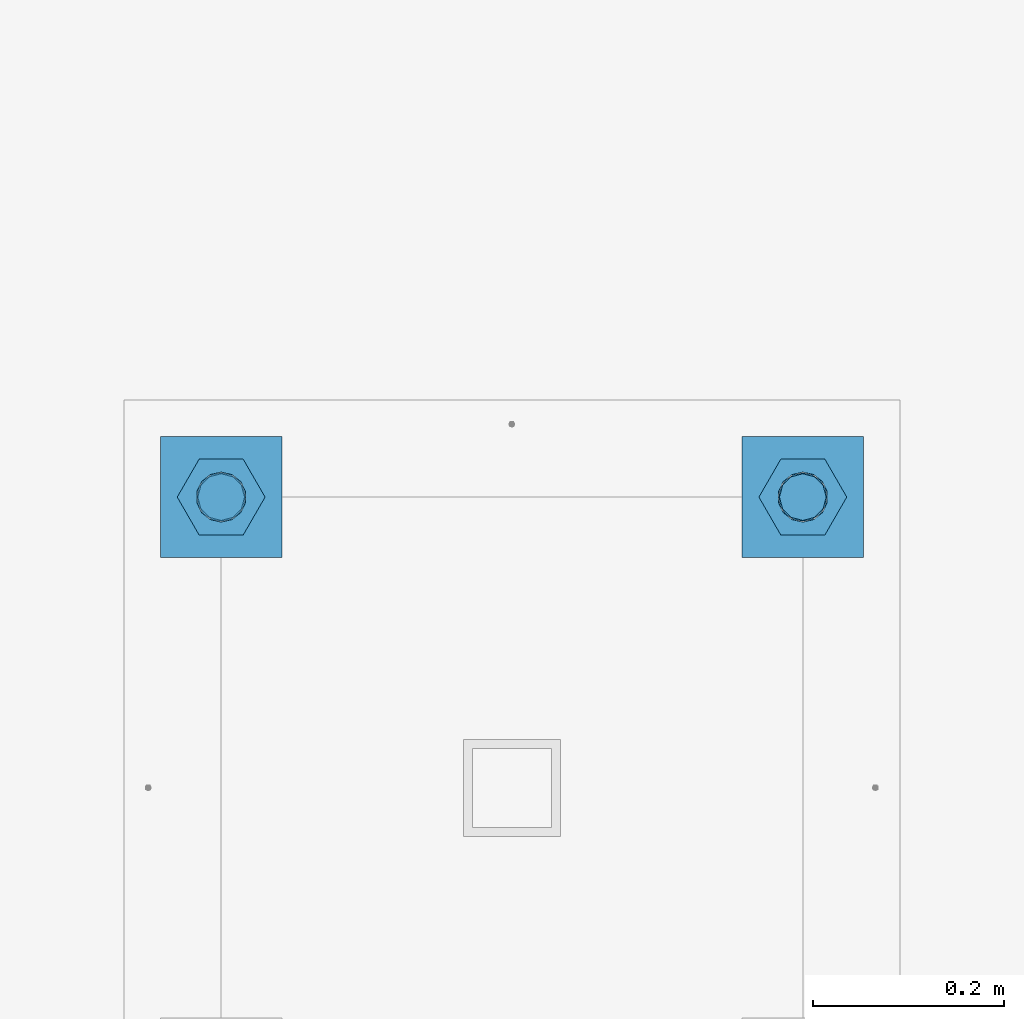
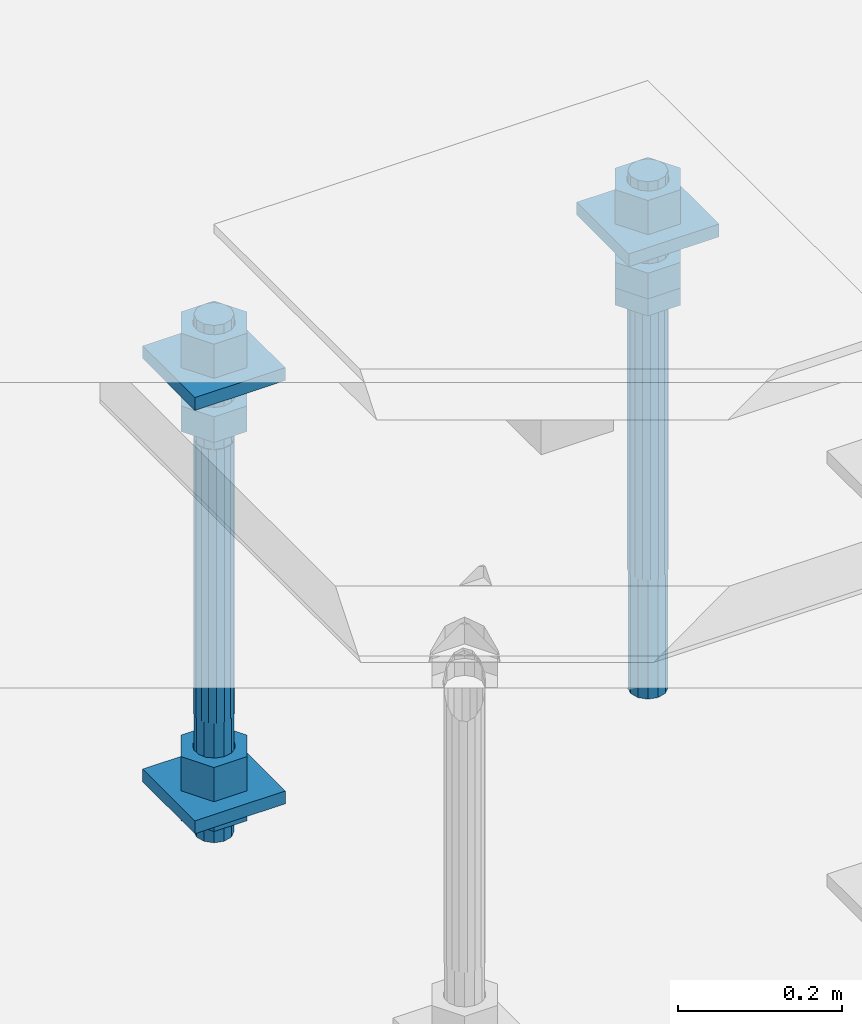
# One storey, part 2744 of 3843: 12 beams, 1 element without a shape of its own.
"""IFC2X3 building model written with IfcOpenShell, lengths in millimetres."""

from ifc_helpers import new_model, si_unit, frame, origin_with_axes, place, context, subcontext, project, spatial, faceted_brep, material, type_object, element, aggregate, save


model = new_model("IFC2X3")

# Units and contexts
model_context = context("Model", 3, precision=1e-05, world=origin_with_axes())
body_context = subcontext(model_context, "Body", "Model", "MODEL_VIEW")
ifc_project = project(units=[si_unit("LENGTHUNIT", "METRE", prefix="MILLI"), si_unit("AREAUNIT", "SQUARE_METRE"), si_unit("VOLUMEUNIT", "CUBIC_METRE"), si_unit("MASSUNIT", "GRAM", prefix="KILO"), si_unit("TIMEUNIT", "SECOND"), si_unit("PLANEANGLEUNIT", "RADIAN"), si_unit("SOLIDANGLEUNIT", "STERADIAN"), si_unit("THERMODYNAMICTEMPERATUREUNIT", "DEGREE_CELSIUS"), si_unit("LUMINOUSINTENSITYUNIT", "LUMEN")], contexts=[model_context])

# Site, building, storey
site_placement = place(None, origin_with_axes())
site = spatial("IfcSite", under=ifc_project, at=site_placement, CompositionType="ELEMENT")
building_placement = place(site_placement, origin_with_axes())
building = spatial("IfcBuilding", under=site, at=building_placement, Name="Undefined", CompositionType="ELEMENT")
storey_placement = place(building_placement, origin_with_axes())
storey = spatial("IfcBuildingStorey", under=building, at=storey_placement, Name="Undefined", CompositionType="ELEMENT", Elevation=0.0)

# Assembly, beams
assembly_placement = place(storey_placement, origin_with_axes())
assembly = element("IfcElementAssembly", 1, at=assembly_placement, inside=storey, Name="TEMPLATE", AssemblyPlace="NOTDEFINED", PredefinedType="RIGID_FRAME")
ifc_material_1 = material(Name="STEEL/A36")
beam_type_1 = type_object("IfcBeamType", PredefinedType="NOTDEFINED")
beam_1_placement = place(assembly_placement, frame((111734.6, 42113.2000015259, 29873.575), z_axis=(1.0, 0.0, 0.0), x_axis=(0.0, 1.0, 0.0)))
beam_1 = element("IfcBeam", 2, at=beam_1_placement, type_object=beam_type_1, material=ifc_material_1, Name="WASHER_PLATE", context=body_context, shape_type="Brep", body=[
    faceted_brep([(0.0, 9.52500000000146, -63.5), (0.0, 9.52500000000146, 63.5), (127.0, 9.52500000000146, 63.5), (127.0, 9.52500000000146, -63.5), (0.0, -9.52500000000146, 63.5), (127.0, -9.52500000000146, 63.5), (0.0, -9.52500000000146, -63.5), (127.0, -9.52500000000146, -63.5)], [[[0, 1, 2, 3]], [[1, 4, 5, 2]], [[4, 6, 7, 5]], [[6, 0, 3, 7]], [[5, 7, 3, 2]], [[6, 4, 1, 0]]]),
])
beam_2_placement = place(assembly_placement, frame((112344.2, 42113.2000015259, 29873.575), z_axis=(1.0, 0.0, 0.0), x_axis=(0.0, 1.0, 0.0)))
beam_2 = element("IfcBeam", 3, at=beam_2_placement, type_object=beam_type_1, material=ifc_material_1, Name="WASHER_PLATE", context=body_context, shape_type="Brep", body=[
    faceted_brep([(0.0, 9.52500000000146, -63.5), (0.0, 9.52500000000146, 63.5), (127.0, 9.52500000000146, 63.5), (127.0, 9.52500000000146, -63.5), (0.0, -9.52500000000146, 63.5), (127.0, -9.52500000000146, 63.5), (0.0, -9.52500000000146, -63.5), (127.0, -9.52500000000146, -63.5)], [[[0, 1, 2, 3]], [[1, 4, 5, 2]], [[4, 6, 7, 5]], [[6, 0, 3, 7]], [[5, 7, 3, 2]], [[6, 4, 1, 0]]]),
])
beam_3_placement = place(assembly_placement, frame((111734.6, 42113.2000015259, 29244.925), z_axis=(1.0, 0.0, 0.0), x_axis=(0.0, 1.0, 0.0)))
beam_3 = element("IfcBeam", 4, at=beam_3_placement, type_object=beam_type_1, material=ifc_material_1, Name="WASHER_PLATE", context=body_context, shape_type="Brep", body=[
    faceted_brep([(0.0, 9.52500000000146, -63.5), (0.0, 9.52500000000146, 63.5), (127.0, 9.52500000000146, 63.5), (127.0, 9.52500000000146, -63.5), (0.0, -9.52500000000146, 63.5), (127.0, -9.52500000000146, 63.5), (0.0, -9.52500000000146, -63.5), (127.0, -9.52500000000146, -63.5)], [[[0, 1, 2, 3]], [[1, 4, 5, 2]], [[4, 6, 7, 5]], [[6, 0, 3, 7]], [[5, 7, 3, 2]], [[6, 4, 1, 0]]]),
])
beam_type_2 = type_object("IfcBeamType", Name="2_HALF_NUT", PredefinedType="NOTDEFINED")
beam_4_placement = place(assembly_placement, frame((112344.2, 42176.7000015259, 29787.85), z_axis=(0.0, 1.0, 0.0), x_axis=(0.0, 0.0, -1.0)))
beam_4 = element("IfcBeam", 5, at=beam_4_placement, type_object=beam_type_2, material=ifc_material_1, Name="NUT", ObjectType="2_HALF_NUT", context=body_context, shape_type="Brep", body=[
    faceted_brep([(0.0, -46.0369987487793, 0.0), (0.0, -23.0184993743896, -39.869213104248), (25.4000000000015, -23.0184993743896, -39.869213104248), (25.4000000000015, -46.0369987487793, 0.0), (0.0, 23.0184993743896, -39.869213104248), (25.4000000000015, 23.0184993743896, -39.869213104248), (0.0, 46.0369987487793, 0.0), (25.4000000000015, 46.0369987487793, 0.0), (0.0, 23.0184993743896, 39.869213104248), (25.4000000000015, 23.0184993743896, 39.869213104248), (0.0, -23.0184993743896, 39.869213104248), (25.4000000000015, -23.0184993743896, 39.869213104248), (0.0, 0.0, 26.1940002441406), (0.0, 11.3650617044477, 23.5999013092805), (25.4000000000015, 11.3650617044477, 23.5999013092805), (25.4000000000015, 0.0, 26.1940002441406), (0.0, 20.4791109456419, 16.3316083006721), (25.4000000000015, 20.4791109456419, 16.3316083006721), (0.0, 25.5370200498292, 5.82867859874386), (25.4000000000015, 25.5370200498292, 5.82867859874386), (0.0, 25.5370200498292, -5.82867859874386), (25.4000000000015, 25.5370200498292, -5.82867859874386), (0.0, 20.4791109456419, -16.3316083006721), (25.4000000000015, 20.4791109456419, -16.3316083006721), (0.0, 11.3650617044477, -23.5999013092805), (25.4000000000015, 11.3650617044477, -23.5999013092805), (0.0, 0.0, -26.1940002441406), (25.4000000000015, 0.0, -26.1940002441406), (0.0, -11.3650617044477, -23.5999013092805), (25.4000000000015, -11.3650617044477, -23.5999013092805), (0.0, -20.4791109456419, -16.3316083006721), (25.4000000000015, -20.4791109456419, -16.3316083006721), (0.0, -25.5370200498292, -5.82867859874386), (25.4000000000015, -25.5370200498292, -5.82867859874386), (0.0, -25.5370200498292, 5.82867859874386), (25.4000000000015, -25.5370200498292, 5.82867859874386), (0.0, -20.4791109456419, 16.3316083006721), (25.4000000000015, -20.4791109456419, 16.3316083006721), (0.0, -11.3650617044477, 23.5999013092805), (25.4000000000015, -11.3650617044477, 23.5999013092805)], [[[0, 1, 2, 3]], [[1, 4, 5, 2]], [[4, 6, 7, 5]], [[6, 8, 9, 7]], [[8, 10, 11, 9]], [[10, 0, 3, 11]], [[12, 13, 14, 15]], [[13, 16, 17, 14]], [[16, 18, 19, 17]], [[18, 20, 21, 19]], [[20, 22, 23, 21]], [[22, 24, 25, 23]], [[24, 26, 27, 25]], [[26, 28, 29, 27]], [[28, 30, 31, 29]], [[30, 32, 33, 31]], [[32, 34, 35, 33]], [[34, 36, 37, 35]], [[36, 38, 39, 37]], [[38, 12, 15, 39]], [[5, 7, 9, 11, 3, 2], [17, 19, 21, 23, 25, 27, 29, 31, 33, 35, 37, 39, 15, 14]], [[10, 8, 6, 4, 1, 0], [38, 36, 34, 32, 30, 28, 26, 24, 22, 20, 18, 16, 13, 12]]]),
])
beam_5_placement = place(assembly_placement, frame((111734.6, 42176.7000015259, 29235.4), z_axis=(0.0, 1.0, 0.0), x_axis=(0.0, 0.0, -1.0)))
beam_5 = element("IfcBeam", 6, at=beam_5_placement, type_object=beam_type_2, material=ifc_material_1, Name="NUT", ObjectType="2_HALF_NUT", context=body_context, shape_type="Brep", body=[
    faceted_brep([(0.0, -46.0369987487793, 0.0), (0.0, -23.0184993743896, -39.869213104248), (25.4000000000015, -23.0184993743896, -39.869213104248), (25.4000000000015, -46.0369987487793, 0.0), (0.0, 23.0184993743896, -39.869213104248), (25.4000000000015, 23.0184993743896, -39.869213104248), (0.0, 46.0369987487793, 0.0), (25.4000000000015, 46.0369987487793, 0.0), (0.0, 23.0184993743896, 39.869213104248), (25.4000000000015, 23.0184993743896, 39.869213104248), (0.0, -23.0184993743896, 39.869213104248), (25.4000000000015, -23.0184993743896, 39.869213104248), (0.0, 0.0, 26.1940002441406), (0.0, 11.3650617044477, 23.5999013092805), (25.4000000000015, 11.3650617044477, 23.5999013092805), (25.4000000000015, 0.0, 26.1940002441406), (0.0, 20.4791109456419, 16.3316083006721), (25.4000000000015, 20.4791109456419, 16.3316083006721), (0.0, 25.5370200498292, 5.82867859874386), (25.4000000000015, 25.5370200498292, 5.82867859874386), (0.0, 25.5370200498292, -5.82867859874386), (25.4000000000015, 25.5370200498292, -5.82867859874386), (0.0, 20.4791109456419, -16.3316083006721), (25.4000000000015, 20.4791109456419, -16.3316083006721), (0.0, 11.3650617044477, -23.5999013092805), (25.4000000000015, 11.3650617044477, -23.5999013092805), (0.0, 0.0, -26.1940002441406), (25.4000000000015, 0.0, -26.1940002441406), (0.0, -11.3650617044477, -23.5999013092805), (25.4000000000015, -11.3650617044477, -23.5999013092805), (0.0, -20.4791109456419, -16.3316083006721), (25.4000000000015, -20.4791109456419, -16.3316083006721), (0.0, -25.5370200498292, -5.82867859874386), (25.4000000000015, -25.5370200498292, -5.82867859874386), (0.0, -25.5370200498292, 5.82867859874386), (25.4000000000015, -25.5370200498292, 5.82867859874386), (0.0, -20.4791109456419, 16.3316083006721), (25.4000000000015, -20.4791109456419, 16.3316083006721), (0.0, -11.3650617044477, 23.5999013092805), (25.4000000000015, -11.3650617044477, 23.5999013092805)], [[[0, 1, 2, 3]], [[1, 4, 5, 2]], [[4, 6, 7, 5]], [[6, 8, 9, 7]], [[8, 10, 11, 9]], [[10, 0, 3, 11]], [[12, 13, 14, 15]], [[13, 16, 17, 14]], [[16, 18, 19, 17]], [[18, 20, 21, 19]], [[20, 22, 23, 21]], [[22, 24, 25, 23]], [[24, 26, 27, 25]], [[26, 28, 29, 27]], [[28, 30, 31, 29]], [[30, 32, 33, 31]], [[32, 34, 35, 33]], [[34, 36, 37, 35]], [[36, 38, 39, 37]], [[38, 12, 15, 39]], [[5, 7, 9, 11, 3, 2], [17, 19, 21, 23, 25, 27, 29, 31, 33, 35, 37, 39, 15, 14]], [[10, 8, 6, 4, 1, 0], [38, 36, 34, 32, 30, 28, 26, 24, 22, 20, 18, 16, 13, 12]]]),
])
beam_type_3 = type_object("IfcBeamType", Name="2_HEAVY_HEX_NUT", PredefinedType="NOTDEFINED")
beam_6_placement = place(assembly_placement, frame((111734.6, 42176.7000015259, 29825.95), z_axis=(0.0, 1.0, 0.0), x_axis=(0.0, 0.0, -1.0)))
beam_6 = element("IfcBeam", 7, at=beam_6_placement, type_object=beam_type_3, material=ifc_material_1, Name="NUT", ObjectType="2_HEAVY_HEX_NUT", context=body_context, shape_type="Brep", body=[
    faceted_brep([(0.0, -46.0369987487793, 0.0), (0.0, -23.0184993743896, -39.869213104248), (38.0999999999985, -23.0184993743896, -39.869213104248), (38.0999999999985, -46.0369987487793, 0.0), (0.0, 23.0184993743896, -39.869213104248), (38.0999999999985, 23.0184993743896, -39.869213104248), (0.0, 46.0369987487793, 0.0), (38.0999999999985, 46.0369987487793, 0.0), (0.0, 23.0184993743896, 39.869213104248), (38.0999999999985, 23.0184993743896, 39.869213104248), (0.0, -23.0184993743896, 39.869213104248), (38.0999999999985, -23.0184993743896, 39.869213104248), (0.0, 0.0, 26.1940002441406), (0.0, 11.3650617044477, 23.5999013092805), (38.0999999999985, 11.3650617044477, 23.5999013092805), (38.0999999999985, 0.0, 26.1940002441406), (0.0, 20.4791109456419, 16.3316083006721), (38.0999999999985, 20.4791109456419, 16.3316083006721), (0.0, 25.5370200498292, 5.82867859874386), (38.0999999999985, 25.5370200498292, 5.82867859874386), (0.0, 25.5370200498292, -5.82867859874386), (38.0999999999985, 25.5370200498292, -5.82867859874386), (0.0, 20.4791109456419, -16.3316083006721), (38.0999999999985, 20.4791109456419, -16.3316083006721), (0.0, 11.3650617044477, -23.5999013092805), (38.0999999999985, 11.3650617044477, -23.5999013092805), (0.0, 0.0, -26.1940002441406), (38.0999999999985, 0.0, -26.1940002441406), (0.0, -11.3650617044477, -23.5999013092805), (38.0999999999985, -11.3650617044477, -23.5999013092805), (0.0, -20.4791109456419, -16.3316083006721), (38.0999999999985, -20.4791109456419, -16.3316083006721), (0.0, -25.5370200498292, -5.82867859874386), (38.0999999999985, -25.5370200498292, -5.82867859874386), (0.0, -25.5370200498292, 5.82867859874386), (38.0999999999985, -25.5370200498292, 5.82867859874386), (0.0, -20.4791109456419, 16.3316083006721), (38.0999999999985, -20.4791109456419, 16.3316083006721), (0.0, -11.3650617044477, 23.5999013092805), (38.0999999999985, -11.3650617044477, 23.5999013092805)], [[[0, 1, 2, 3]], [[1, 4, 5, 2]], [[4, 6, 7, 5]], [[6, 8, 9, 7]], [[8, 10, 11, 9]], [[10, 0, 3, 11]], [[12, 13, 14, 15]], [[13, 16, 17, 14]], [[16, 18, 19, 17]], [[18, 20, 21, 19]], [[20, 22, 23, 21]], [[22, 24, 25, 23]], [[24, 26, 27, 25]], [[26, 28, 29, 27]], [[28, 30, 31, 29]], [[30, 32, 33, 31]], [[32, 34, 35, 33]], [[34, 36, 37, 35]], [[36, 38, 39, 37]], [[38, 12, 15, 39]], [[5, 7, 9, 11, 3, 2], [17, 19, 21, 23, 25, 27, 29, 31, 33, 35, 37, 39, 15, 14]], [[10, 8, 6, 4, 1, 0], [38, 36, 34, 32, 30, 28, 26, 24, 22, 20, 18, 16, 13, 12]]]),
])
beam_7_placement = place(assembly_placement, frame((111734.6, 42176.7000015259, 29933.9), z_axis=(0.0, 1.0, 0.0), x_axis=(0.0, 0.0, -1.0)))
beam_7 = element("IfcBeam", 8, at=beam_7_placement, type_object=beam_type_3, material=ifc_material_1, Name="NUT", ObjectType="2_HEAVY_HEX_NUT", context=body_context, shape_type="Brep", body=[
    faceted_brep([(0.0, -46.0369987487793, 0.0), (0.0, -23.0184993743896, -39.869213104248), (50.7999999999993, -23.0184993743896, -39.869213104248), (50.7999999999993, -46.0369987487793, 0.0), (0.0, 23.0184993743896, -39.869213104248), (50.7999999999993, 23.0184993743896, -39.869213104248), (0.0, 46.0369987487793, 0.0), (50.7999999999993, 46.0369987487793, 0.0), (0.0, 23.0184993743896, 39.869213104248), (50.7999999999993, 23.0184993743896, 39.869213104248), (0.0, -23.0184993743896, 39.869213104248), (50.7999999999993, -23.0184993743896, 39.869213104248), (0.0, 0.0, 26.1940002441406), (0.0, 11.3650617044477, 23.5999013092805), (50.7999999999993, 11.3650617044477, 23.5999013092805), (50.7999999999993, 0.0, 26.1940002441406), (0.0, 20.4791109456419, 16.3316083006721), (50.7999999999993, 20.4791109456419, 16.3316083006721), (0.0, 25.5370200498292, 5.82867859874386), (50.7999999999993, 25.5370200498292, 5.82867859874386), (0.0, 25.5370200498292, -5.82867859874386), (50.7999999999993, 25.5370200498292, -5.82867859874386), (0.0, 20.4791109456419, -16.3316083006721), (50.7999999999993, 20.4791109456419, -16.3316083006721), (0.0, 11.3650617044477, -23.5999013092805), (50.7999999999993, 11.3650617044477, -23.5999013092805), (0.0, 0.0, -26.1940002441406), (50.7999999999993, 0.0, -26.1940002441406), (0.0, -11.3650617044477, -23.5999013092805), (50.7999999999993, -11.3650617044477, -23.5999013092805), (0.0, -20.4791109456419, -16.3316083006721), (50.7999999999993, -20.4791109456419, -16.3316083006721), (0.0, -25.5370200498292, -5.82867859874386), (50.7999999999993, -25.5370200498292, -5.82867859874386), (0.0, -25.5370200498292, 5.82867859874386), (50.7999999999993, -25.5370200498292, 5.82867859874386), (0.0, -20.4791109456419, 16.3316083006721), (50.7999999999993, -20.4791109456419, 16.3316083006721), (0.0, -11.3650617044477, 23.5999013092805), (50.7999999999993, -11.3650617044477, 23.5999013092805)], [[[0, 1, 2, 3]], [[1, 4, 5, 2]], [[4, 6, 7, 5]], [[6, 8, 9, 7]], [[8, 10, 11, 9]], [[10, 0, 3, 11]], [[12, 13, 14, 15]], [[13, 16, 17, 14]], [[16, 18, 19, 17]], [[18, 20, 21, 19]], [[20, 22, 23, 21]], [[22, 24, 25, 23]], [[24, 26, 27, 25]], [[26, 28, 29, 27]], [[28, 30, 31, 29]], [[30, 32, 33, 31]], [[32, 34, 35, 33]], [[34, 36, 37, 35]], [[36, 38, 39, 37]], [[38, 12, 15, 39]], [[5, 7, 9, 11, 3, 2], [17, 19, 21, 23, 25, 27, 29, 31, 33, 35, 37, 39, 15, 14]], [[10, 8, 6, 4, 1, 0], [38, 36, 34, 32, 30, 28, 26, 24, 22, 20, 18, 16, 13, 12]]]),
])
beam_8_placement = place(assembly_placement, frame((111734.6, 42176.7000015259, 29305.25), z_axis=(0.0, 1.0, 0.0), x_axis=(0.0, 0.0, -1.0)))
beam_8 = element("IfcBeam", 9, at=beam_8_placement, type_object=beam_type_3, material=ifc_material_1, Name="NUT", ObjectType="2_HEAVY_HEX_NUT", context=body_context, shape_type="Brep", body=[
    faceted_brep([(0.0, -46.0369987487793, 0.0), (0.0, -23.0184993743896, -39.869213104248), (50.7999999999993, -23.0184993743896, -39.869213104248), (50.7999999999993, -46.0369987487793, 0.0), (0.0, 23.0184993743896, -39.869213104248), (50.7999999999993, 23.0184993743896, -39.869213104248), (0.0, 46.0369987487793, 0.0), (50.7999999999993, 46.0369987487793, 0.0), (0.0, 23.0184993743896, 39.869213104248), (50.7999999999993, 23.0184993743896, 39.869213104248), (0.0, -23.0184993743896, 39.869213104248), (50.7999999999993, -23.0184993743896, 39.869213104248), (0.0, 0.0, 26.1940002441406), (0.0, 11.3650617044477, 23.5999013092805), (50.7999999999993, 11.3650617044477, 23.5999013092805), (50.7999999999993, 0.0, 26.1940002441406), (0.0, 20.4791109456419, 16.3316083006721), (50.7999999999993, 20.4791109456419, 16.3316083006721), (0.0, 25.5370200498292, 5.82867859874386), (50.7999999999993, 25.5370200498292, 5.82867859874386), (0.0, 25.5370200498292, -5.82867859874386), (50.7999999999993, 25.5370200498292, -5.82867859874386), (0.0, 20.4791109456419, -16.3316083006721), (50.7999999999993, 20.4791109456419, -16.3316083006721), (0.0, 11.3650617044477, -23.5999013092805), (50.7999999999993, 11.3650617044477, -23.5999013092805), (0.0, 0.0, -26.1940002441406), (50.7999999999993, 0.0, -26.1940002441406), (0.0, -11.3650617044477, -23.5999013092805), (50.7999999999993, -11.3650617044477, -23.5999013092805), (0.0, -20.4791109456419, -16.3316083006721), (50.7999999999993, -20.4791109456419, -16.3316083006721), (0.0, -25.5370200498292, -5.82867859874386), (50.7999999999993, -25.5370200498292, -5.82867859874386), (0.0, -25.5370200498292, 5.82867859874386), (50.7999999999993, -25.5370200498292, 5.82867859874386), (0.0, -20.4791109456419, 16.3316083006721), (50.7999999999993, -20.4791109456419, 16.3316083006721), (0.0, -11.3650617044477, 23.5999013092805), (50.7999999999993, -11.3650617044477, 23.5999013092805)], [[[0, 1, 2, 3]], [[1, 4, 5, 2]], [[4, 6, 7, 5]], [[6, 8, 9, 7]], [[8, 10, 11, 9]], [[10, 0, 3, 11]], [[12, 13, 14, 15]], [[13, 16, 17, 14]], [[16, 18, 19, 17]], [[18, 20, 21, 19]], [[20, 22, 23, 21]], [[22, 24, 25, 23]], [[24, 26, 27, 25]], [[26, 28, 29, 27]], [[28, 30, 31, 29]], [[30, 32, 33, 31]], [[32, 34, 35, 33]], [[34, 36, 37, 35]], [[36, 38, 39, 37]], [[38, 12, 15, 39]], [[5, 7, 9, 11, 3, 2], [17, 19, 21, 23, 25, 27, 29, 31, 33, 35, 37, 39, 15, 14]], [[10, 8, 6, 4, 1, 0], [38, 36, 34, 32, 30, 28, 26, 24, 22, 20, 18, 16, 13, 12]]]),
])
beam_9_placement = place(assembly_placement, frame((112344.2, 42176.7000015259, 29825.95), z_axis=(0.0, 1.0, 0.0), x_axis=(0.0, 0.0, -1.0)))
beam_9 = element("IfcBeam", 10, at=beam_9_placement, type_object=beam_type_3, material=ifc_material_1, Name="NUT", ObjectType="2_HEAVY_HEX_NUT", context=body_context, shape_type="Brep", body=[
    faceted_brep([(0.0, -46.0369987487793, 0.0), (0.0, -23.0184993743896, -39.869213104248), (38.0999999999985, -23.0184993743896, -39.869213104248), (38.0999999999985, -46.0369987487793, 0.0), (0.0, 23.0184993743896, -39.869213104248), (38.0999999999985, 23.0184993743896, -39.869213104248), (0.0, 46.0369987487793, 0.0), (38.0999999999985, 46.0369987487793, 0.0), (0.0, 23.0184993743896, 39.869213104248), (38.0999999999985, 23.0184993743896, 39.869213104248), (0.0, -23.0184993743896, 39.869213104248), (38.0999999999985, -23.0184993743896, 39.869213104248), (0.0, 0.0, 26.1940002441406), (0.0, 11.3650617044477, 23.5999013092805), (38.0999999999985, 11.3650617044477, 23.5999013092805), (38.0999999999985, 0.0, 26.1940002441406), (0.0, 20.4791109456419, 16.3316083006721), (38.0999999999985, 20.4791109456419, 16.3316083006721), (0.0, 25.5370200498292, 5.82867859874386), (38.0999999999985, 25.5370200498292, 5.82867859874386), (0.0, 25.5370200498292, -5.82867859874386), (38.0999999999985, 25.5370200498292, -5.82867859874386), (0.0, 20.4791109456419, -16.3316083006721), (38.0999999999985, 20.4791109456419, -16.3316083006721), (0.0, 11.3650617044477, -23.5999013092805), (38.0999999999985, 11.3650617044477, -23.5999013092805), (0.0, 0.0, -26.1940002441406), (38.0999999999985, 0.0, -26.1940002441406), (0.0, -11.3650617044477, -23.5999013092805), (38.0999999999985, -11.3650617044477, -23.5999013092805), (0.0, -20.4791109456419, -16.3316083006721), (38.0999999999985, -20.4791109456419, -16.3316083006721), (0.0, -25.5370200498292, -5.82867859874386), (38.0999999999985, -25.5370200498292, -5.82867859874386), (0.0, -25.5370200498292, 5.82867859874386), (38.0999999999985, -25.5370200498292, 5.82867859874386), (0.0, -20.4791109456419, 16.3316083006721), (38.0999999999985, -20.4791109456419, 16.3316083006721), (0.0, -11.3650617044477, 23.5999013092805), (38.0999999999985, -11.3650617044477, 23.5999013092805)], [[[0, 1, 2, 3]], [[1, 4, 5, 2]], [[4, 6, 7, 5]], [[6, 8, 9, 7]], [[8, 10, 11, 9]], [[10, 0, 3, 11]], [[12, 13, 14, 15]], [[13, 16, 17, 14]], [[16, 18, 19, 17]], [[18, 20, 21, 19]], [[20, 22, 23, 21]], [[22, 24, 25, 23]], [[24, 26, 27, 25]], [[26, 28, 29, 27]], [[28, 30, 31, 29]], [[30, 32, 33, 31]], [[32, 34, 35, 33]], [[34, 36, 37, 35]], [[36, 38, 39, 37]], [[38, 12, 15, 39]], [[5, 7, 9, 11, 3, 2], [17, 19, 21, 23, 25, 27, 29, 31, 33, 35, 37, 39, 15, 14]], [[10, 8, 6, 4, 1, 0], [38, 36, 34, 32, 30, 28, 26, 24, 22, 20, 18, 16, 13, 12]]]),
])
beam_10_placement = place(assembly_placement, frame((112344.2, 42176.7000015259, 29933.9), z_axis=(0.0, 1.0, 0.0), x_axis=(0.0, 0.0, -1.0)))
beam_10 = element("IfcBeam", 11, at=beam_10_placement, type_object=beam_type_3, material=ifc_material_1, Name="NUT", ObjectType="2_HEAVY_HEX_NUT", context=body_context, shape_type="Brep", body=[
    faceted_brep([(0.0, -46.0369987487793, 0.0), (0.0, -23.0184993743896, -39.869213104248), (50.7999999999993, -23.0184993743896, -39.869213104248), (50.7999999999993, -46.0369987487793, 0.0), (0.0, 23.0184993743896, -39.869213104248), (50.7999999999993, 23.0184993743896, -39.869213104248), (0.0, 46.0369987487793, 0.0), (50.7999999999993, 46.0369987487793, 0.0), (0.0, 23.0184993743896, 39.869213104248), (50.7999999999993, 23.0184993743896, 39.869213104248), (0.0, -23.0184993743896, 39.869213104248), (50.7999999999993, -23.0184993743896, 39.869213104248), (0.0, 0.0, 26.1940002441406), (0.0, 11.3650617044477, 23.5999013092805), (50.7999999999993, 11.3650617044477, 23.5999013092805), (50.7999999999993, 0.0, 26.1940002441406), (0.0, 20.4791109456419, 16.3316083006721), (50.7999999999993, 20.4791109456419, 16.3316083006721), (0.0, 25.5370200498292, 5.82867859874386), (50.7999999999993, 25.5370200498292, 5.82867859874386), (0.0, 25.5370200498292, -5.82867859874386), (50.7999999999993, 25.5370200498292, -5.82867859874386), (0.0, 20.4791109456419, -16.3316083006721), (50.7999999999993, 20.4791109456419, -16.3316083006721), (0.0, 11.3650617044477, -23.5999013092805), (50.7999999999993, 11.3650617044477, -23.5999013092805), (0.0, 0.0, -26.1940002441406), (50.7999999999993, 0.0, -26.1940002441406), (0.0, -11.3650617044477, -23.5999013092805), (50.7999999999993, -11.3650617044477, -23.5999013092805), (0.0, -20.4791109456419, -16.3316083006721), (50.7999999999993, -20.4791109456419, -16.3316083006721), (0.0, -25.5370200498292, -5.82867859874386), (50.7999999999993, -25.5370200498292, -5.82867859874386), (0.0, -25.5370200498292, 5.82867859874386), (50.7999999999993, -25.5370200498292, 5.82867859874386), (0.0, -20.4791109456419, 16.3316083006721), (50.7999999999993, -20.4791109456419, 16.3316083006721), (0.0, -11.3650617044477, 23.5999013092805), (50.7999999999993, -11.3650617044477, 23.5999013092805)], [[[0, 1, 2, 3]], [[1, 4, 5, 2]], [[4, 6, 7, 5]], [[6, 8, 9, 7]], [[8, 10, 11, 9]], [[10, 0, 3, 11]], [[12, 13, 14, 15]], [[13, 16, 17, 14]], [[16, 18, 19, 17]], [[18, 20, 21, 19]], [[20, 22, 23, 21]], [[22, 24, 25, 23]], [[24, 26, 27, 25]], [[26, 28, 29, 27]], [[28, 30, 31, 29]], [[30, 32, 33, 31]], [[32, 34, 35, 33]], [[34, 36, 37, 35]], [[36, 38, 39, 37]], [[38, 12, 15, 39]], [[5, 7, 9, 11, 3, 2], [17, 19, 21, 23, 25, 27, 29, 31, 33, 35, 37, 39, 15, 14]], [[10, 8, 6, 4, 1, 0], [38, 36, 34, 32, 30, 28, 26, 24, 22, 20, 18, 16, 13, 12]]]),
])
ifc_material_2 = material()
beam_type_4 = type_object("IfcBeamType", PredefinedType="NOTDEFINED")
beam_11_placement = place(assembly_placement, frame((111734.6, 42176.7000015259, 29762.45), z_axis=(0.0, 1.0, 0.0), x_axis=(0.0, 0.0, -1.0)))
beam_11 = element("IfcBeam", 12, at=beam_11_placement, type_object=beam_type_4, material=ifc_material_2, Name="ANCHOR_ROD", context=body_context, shape_type="Brep", body=[
    faceted_brep([(-184.150000000001, -21.217622392709, 12.25), (-184.150000000001, -12.2499999999854, 21.2176223927163), (-184.150000000001, 1.45519152283669e-11, 24.5), (-184.150000000001, 12.2500000000146, 21.2176223927163), (-184.150000000001, 21.2176223927381, 12.25), (-184.150000000001, 24.5000000000146, 0.0), (-184.150000000001, 21.2176223927381, -12.25), (-184.150000000001, 12.2500000000146, -21.2176223927163), (-184.150000000001, 1.45519152283669e-11, -24.5), (-184.150000000001, -12.2499999999854, -21.2176223927163), (-184.150000000001, -21.217622392709, -12.25), (-184.150000000001, -24.4999999999854, 0.0), (0.0, 24.5000000000146, 0.0), (0.0, 21.2176223927381, -12.25), (0.0, 12.2500000000146, -21.2176223927163), (0.0, 1.45519152283669e-11, -24.5), (0.0, -12.2499999999854, -21.2176223927163), (0.0, -21.217622392709, -12.25), (0.0, -24.4999999999854, 0.0), (0.0, -21.217622392709, 12.25), (0.0, -12.2499999999854, 21.2176223927163), (0.0, 1.45519152283669e-11, 24.5), (0.0, 12.2500000000146, 21.2176223927163), (0.0, 21.2176223927381, 12.25), (0.0, -23.4665401257807, 9.72015918207035), (0.0, -17.9605122421344, 17.9605122421417), (0.0, -9.72015918207762, 23.466540125788), (0.0, 0.0, 25.4000000000015), (0.0, 9.72015918207762, 23.466540125788), (0.0, 17.9605122421344, 17.9605122421417), (0.0, 23.4665401257807, 9.72015918207035), (0.0, 25.3999996185303, 0.0), (0.0, 23.4665401257807, -9.72015918207035), (0.0, 17.9605122421344, -17.9605122421417), (0.0, 9.72015918207762, -23.466540125788), (0.0, 0.0, -25.4000000000015), (0.0, -9.72015918207762, -23.466540125788), (0.0, -17.9605122421344, -17.9605122421417), (0.0, -23.4665401257807, -9.72015918207035), (0.0, -25.3999996185303, 0.0), (406.399999999998, -25.3999999999942, 0.0), (406.399999999998, -23.4665401257807, 9.72015918207035), (406.399999999998, -17.9605122421344, 17.9605122421417), (406.399999999998, -9.72015918207762, 23.466540125788), (406.399999999998, 0.0, 25.4000000000015), (406.399999999998, 9.72015918207762, 23.466540125788), (406.399999999998, 17.9605122421344, 17.9605122421417), (406.399999999998, 23.4665401257807, 9.72015918207035), (406.399999999998, 25.3999999999942, 0.0), (406.399999999998, 23.4665401257807, -9.72015918207035), (406.399999999998, 17.9605122421344, -17.9605122421417), (406.399999999998, 9.72015918207762, -23.466540125788), (406.399999999998, 0.0, -25.4000000000015), (406.399999999998, -9.72015918207762, -23.466540125788), (406.399999999998, -17.9605122421344, -17.9605122421417), (406.399999999998, -23.4665401257807, -9.72015918207035), (406.399999999998, -12.2499999999854, 21.2176223927163), (406.399999999998, 1.45519152283669e-11, 24.5), (406.399999999998, 12.2500000000146, 21.2176223927163), (406.399999999998, 21.2176223927381, 12.25), (406.399999999998, 24.5000000000146, 0.0), (406.399999999998, 21.2176223927381, -12.25), (406.399999999998, 12.2500000000146, -21.2176223927163), (406.399999999998, 1.45519152283669e-11, -24.5), (406.399999999998, -12.2499999999854, -21.2176223927163), (406.399999999998, -21.217622392709, -12.25), (406.399999999998, -24.4999999999854, 0.0), (406.399999999998, -21.217622392709, 12.25), (584.200000000001, -12.2499999999854, -21.2176223927163), (584.200000000001, 1.45519152283669e-11, -24.5), (584.200000000001, 12.2500000000146, -21.2176223927163), (584.200000000001, 21.2176223927381, -12.25), (584.200000000001, 24.5000000000146, 0.0), (584.200000000001, 21.2176223927381, 12.25), (584.200000000001, 12.2500000000146, 21.2176223927163), (584.200000000001, 1.45519152283669e-11, 24.5), (584.200000000001, -12.2499999999854, 21.2176223927163), (584.200000000001, -21.217622392709, 12.25), (584.200000000001, -24.4999999999854, 0.0), (584.200000000001, -21.217622392709, -12.25)], [[[0, 1, 2, 3, 4, 5, 6, 7, 8, 9, 10, 11]], [[6, 5, 12, 13]], [[7, 6, 13, 14]], [[8, 7, 14, 15]], [[9, 8, 15, 16]], [[10, 9, 16, 17]], [[11, 10, 17, 18]], [[0, 11, 18, 19]], [[1, 0, 19, 20]], [[2, 1, 20, 21]], [[3, 2, 21, 22]], [[4, 3, 22, 23]], [[5, 4, 23, 12]], [[24, 25, 26, 27, 28, 29, 30, 31, 32, 33, 34, 35, 36, 37, 38, 39], [22, 21, 20, 19, 18, 17, 16, 15, 14, 13, 12, 23]], [[24, 39, 40, 41]], [[25, 24, 41, 42]], [[26, 25, 42, 43]], [[27, 26, 43, 44]], [[28, 27, 44, 45]], [[29, 28, 45, 46]], [[30, 29, 46, 47]], [[31, 30, 47, 48]], [[32, 31, 48, 49]], [[33, 32, 49, 50]], [[34, 33, 50, 51]], [[35, 34, 51, 52]], [[36, 35, 52, 53]], [[37, 36, 53, 54]], [[38, 37, 54, 55]], [[39, 38, 55, 40]], [[54, 53, 52, 51, 50, 49, 48, 47, 46, 45, 44, 43, 42, 41, 40, 55], [56, 57, 58, 59, 60, 61, 62, 63, 64, 65, 66, 67]], [[68, 69, 70, 71, 72, 73, 74, 75, 76, 77, 78, 79]], [[76, 75, 57, 56]], [[77, 76, 56, 67]], [[78, 77, 67, 66]], [[79, 78, 66, 65]], [[68, 79, 65, 64]], [[69, 68, 64, 63]], [[70, 69, 63, 62]], [[71, 70, 62, 61]], [[72, 71, 61, 60]], [[73, 72, 60, 59]], [[74, 73, 59, 58]], [[75, 74, 58, 57]]]),
])
beam_12_placement = place(assembly_placement, frame((112344.2, 42176.7000015259, 29762.45), z_axis=(0.0, 1.0, 0.0), x_axis=(0.0, 0.0, -1.0)))
beam_12 = element("IfcBeam", 13, at=beam_12_placement, type_object=beam_type_4, material=ifc_material_2, Name="ANCHOR_ROD", context=body_context, shape_type="Brep", body=[
    faceted_brep([(-184.150000000001, -21.217622392709, 12.25), (-184.150000000001, -12.2499999999854, 21.2176223927163), (-184.150000000001, 1.45519152283669e-11, 24.5), (-184.150000000001, 12.2500000000146, 21.2176223927163), (-184.150000000001, 21.2176223927381, 12.25), (-184.150000000001, 24.5000000000146, 0.0), (-184.150000000001, 21.2176223927381, -12.25), (-184.150000000001, 12.2500000000146, -21.2176223927163), (-184.150000000001, 1.45519152283669e-11, -24.5), (-184.150000000001, -12.2499999999854, -21.2176223927163), (-184.150000000001, -21.217622392709, -12.25), (-184.150000000001, -24.4999999999854, 0.0), (0.0, 24.5000000000146, 0.0), (0.0, 21.2176223927381, -12.25), (0.0, 12.2500000000146, -21.2176223927163), (0.0, 1.45519152283669e-11, -24.5), (0.0, -12.2499999999854, -21.2176223927163), (0.0, -21.217622392709, -12.25), (0.0, -24.4999999999854, 0.0), (0.0, -21.217622392709, 12.25), (0.0, -12.2499999999854, 21.2176223927163), (0.0, 1.45519152283669e-11, 24.5), (0.0, 12.2500000000146, 21.2176223927163), (0.0, 21.2176223927381, 12.25), (0.0, -23.4665401257807, 9.72015918207035), (0.0, -17.9605122421344, 17.9605122421417), (0.0, -9.72015918207762, 23.466540125788), (0.0, 0.0, 25.4000000000015), (0.0, 9.72015918207762, 23.466540125788), (0.0, 17.9605122421344, 17.9605122421417), (0.0, 23.4665401257807, 9.72015918207035), (0.0, 25.3999996185303, 0.0), (0.0, 23.4665401257807, -9.72015918207035), (0.0, 17.9605122421344, -17.9605122421417), (0.0, 9.72015918207762, -23.466540125788), (0.0, 0.0, -25.4000000000015), (0.0, -9.72015918207762, -23.466540125788), (0.0, -17.9605122421344, -17.9605122421417), (0.0, -23.4665401257807, -9.72015918207035), (0.0, -25.3999996185303, 0.0), (406.399999999998, -25.3999999999942, 0.0), (406.399999999998, -23.4665401257807, 9.72015918207035), (406.399999999998, -17.9605122421344, 17.9605122421417), (406.399999999998, -9.72015918207762, 23.466540125788), (406.399999999998, 0.0, 25.4000000000015), (406.399999999998, 9.72015918207762, 23.466540125788), (406.399999999998, 17.9605122421344, 17.9605122421417), (406.399999999998, 23.4665401257807, 9.72015918207035), (406.399999999998, 25.3999999999942, 0.0), (406.399999999998, 23.4665401257807, -9.72015918207035), (406.399999999998, 17.9605122421344, -17.9605122421417), (406.399999999998, 9.72015918207762, -23.466540125788), (406.399999999998, 0.0, -25.4000000000015), (406.399999999998, -9.72015918207762, -23.466540125788), (406.399999999998, -17.9605122421344, -17.9605122421417), (406.399999999998, -23.4665401257807, -9.72015918207035), (406.399999999998, -12.2499999999854, 21.2176223927163), (406.399999999998, 1.45519152283669e-11, 24.5), (406.399999999998, 12.2500000000146, 21.2176223927163), (406.399999999998, 21.2176223927381, 12.25), (406.399999999998, 24.5000000000146, 0.0), (406.399999999998, 21.2176223927381, -12.25), (406.399999999998, 12.2500000000146, -21.2176223927163), (406.399999999998, 1.45519152283669e-11, -24.5), (406.399999999998, -12.2499999999854, -21.2176223927163), (406.399999999998, -21.217622392709, -12.25), (406.399999999998, -24.4999999999854, 0.0), (406.399999999998, -21.217622392709, 12.25), (584.200000000001, -12.2499999999854, -21.2176223927163), (584.200000000001, 1.45519152283669e-11, -24.5), (584.200000000001, 12.2500000000146, -21.2176223927163), (584.200000000001, 21.2176223927381, -12.25), (584.200000000001, 24.5000000000146, 0.0), (584.200000000001, 21.2176223927381, 12.25), (584.200000000001, 12.2500000000146, 21.2176223927163), (584.200000000001, 1.45519152283669e-11, 24.5), (584.200000000001, -12.2499999999854, 21.2176223927163), (584.200000000001, -21.217622392709, 12.25), (584.200000000001, -24.4999999999854, 0.0), (584.200000000001, -21.217622392709, -12.25)], [[[0, 1, 2, 3, 4, 5, 6, 7, 8, 9, 10, 11]], [[6, 5, 12, 13]], [[7, 6, 13, 14]], [[8, 7, 14, 15]], [[9, 8, 15, 16]], [[10, 9, 16, 17]], [[11, 10, 17, 18]], [[0, 11, 18, 19]], [[1, 0, 19, 20]], [[2, 1, 20, 21]], [[3, 2, 21, 22]], [[4, 3, 22, 23]], [[5, 4, 23, 12]], [[24, 25, 26, 27, 28, 29, 30, 31, 32, 33, 34, 35, 36, 37, 38, 39], [22, 21, 20, 19, 18, 17, 16, 15, 14, 13, 12, 23]], [[24, 39, 40, 41]], [[25, 24, 41, 42]], [[26, 25, 42, 43]], [[27, 26, 43, 44]], [[28, 27, 44, 45]], [[29, 28, 45, 46]], [[30, 29, 46, 47]], [[31, 30, 47, 48]], [[32, 31, 48, 49]], [[33, 32, 49, 50]], [[34, 33, 50, 51]], [[35, 34, 51, 52]], [[36, 35, 52, 53]], [[37, 36, 53, 54]], [[38, 37, 54, 55]], [[39, 38, 55, 40]], [[54, 53, 52, 51, 50, 49, 48, 47, 46, 45, 44, 43, 42, 41, 40, 55], [56, 57, 58, 59, 60, 61, 62, 63, 64, 65, 66, 67]], [[68, 69, 70, 71, 72, 73, 74, 75, 76, 77, 78, 79]], [[76, 75, 57, 56]], [[77, 76, 56, 67]], [[78, 77, 67, 66]], [[79, 78, 66, 65]], [[68, 79, 65, 64]], [[69, 68, 64, 63]], [[70, 69, 63, 62]], [[71, 70, 62, 61]], [[72, 71, 61, 60]], [[73, 72, 60, 59]], [[74, 73, 59, 58]], [[75, 74, 58, 57]]]),
])
aggregate(assembly, [beam_4, beam_1, beam_2, beam_11, beam_6, beam_7, beam_8, beam_5, beam_3, beam_12, beam_9, beam_10])

save(model, "model.ifc")
